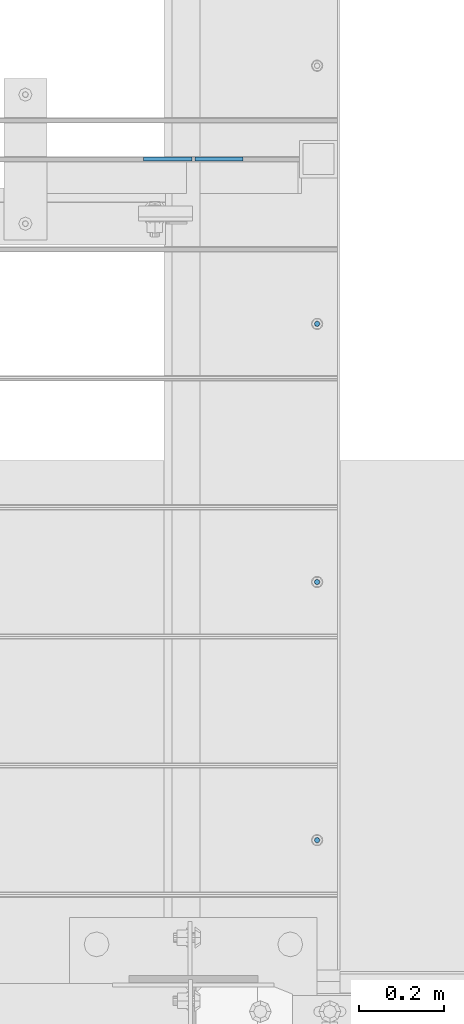
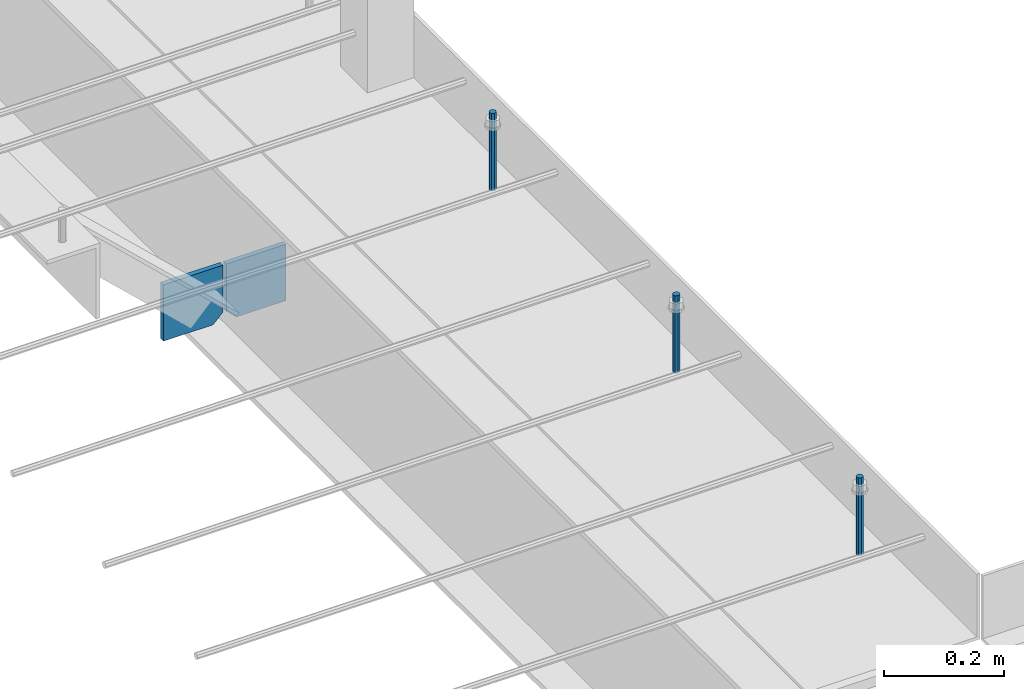
# One storey, part 385 of 1179: 5 columns, 1 element without a shape of its own.
"""IFC2X3 building model written with IfcOpenShell, lengths in millimetres."""

from ifc_helpers import new_model, si_unit, frame, origin_with_axes, place, context, subcontext, project, spatial, faceted_brep, material, type_object, element, aggregate, save


model = new_model("IFC2X3")

# Units and contexts
model_context = context("Model", 3, precision=1e-05, world=origin_with_axes())
body_context = subcontext(model_context, "Body", "Model", "MODEL_VIEW")
ifc_project = project(units=[si_unit("LENGTHUNIT", "METRE", prefix="MILLI"), si_unit("AREAUNIT", "SQUARE_METRE"), si_unit("VOLUMEUNIT", "CUBIC_METRE"), si_unit("MASSUNIT", "GRAM", prefix="KILO"), si_unit("TIMEUNIT", "SECOND"), si_unit("PLANEANGLEUNIT", "RADIAN"), si_unit("SOLIDANGLEUNIT", "STERADIAN"), si_unit("THERMODYNAMICTEMPERATUREUNIT", "DEGREE_CELSIUS"), si_unit("LUMINOUSINTENSITYUNIT", "LUMEN")], contexts=[model_context])

# Site, building, storey
site_placement = place(None, origin_with_axes())
site = spatial("IfcSite", under=ifc_project, at=site_placement, CompositionType="ELEMENT")
building_placement = place(site_placement, origin_with_axes())
building = spatial("IfcBuilding", under=site, at=building_placement, Name="Undefined", CompositionType="ELEMENT")
storey_placement = place(building_placement, origin_with_axes())
storey = spatial("IfcBuildingStorey", under=building, at=storey_placement, Name="Undefined", CompositionType="ELEMENT", Elevation=0.0)

# Assembly, columns
assembly_placement = place(storey_placement, origin_with_axes())
assembly = element("IfcElementAssembly", 1, at=assembly_placement, inside=storey, Name="BEAM", AssemblyPlace="NOTDEFINED", PredefinedType="RIGID_FRAME")
ifc_material_1 = material(Name="STEEL/A36")
column_type_1 = type_object("IfcColumnType", PredefinedType="NOTDEFINED")
column_1_placement = place(assembly_placement, frame((8220.075, 7518.40000000001, 3709.9875), z_axis=(1.0, 0.0, 0.0), x_axis=(0.0, 0.0, 1.0)))
column_1 = element("IfcColumn", 2, at=column_1_placement, type_object=column_type_1, material=ifc_material_1, Name="PLATE", context=body_context, shape_type="Brep", body=[
    faceted_brep([(19.0500000000002, 4.76250000000073, 57.1500000000015), (0.0, 4.76250000000073, 38.0999999999985), (0.0, -4.76250000000073, 38.0999999999985), (19.0500000000002, -4.76250000000073, 57.1500000000015), (114.300000000001, 4.76250000000073, 57.1500000000015), (114.300000000001, 4.76250000000073, -57.1500000000015), (0.0, 4.76250000000073, -57.1500000000015), (114.300000000001, -4.76250000000073, 57.1500000000015), (0.0, -4.76250000000073, -57.1500000000015), (114.300000000001, -4.76250000000073, -57.1500000000015)], [[[0, 1, 2, 3]], [[4, 5, 6, 1, 0]], [[7, 4, 0, 3]], [[8, 9, 7, 3, 2]], [[8, 6, 5, 9]], [[7, 9, 5, 4]], [[6, 8, 2, 1]]]),
])
column_2_placement = place(assembly_placement, frame((8340.725, 7518.40000000001, 3709.9875), z_axis=(-1.0, 0.0, 0.0), x_axis=(0.0, 0.0, 1.0)))
column_2 = element("IfcColumn", 3, at=column_2_placement, type_object=column_type_1, material=ifc_material_1, Name="PLATE", context=body_context, shape_type="Brep", body=[
    faceted_brep([(19.0500000000002, 4.76250000000073, 57.1500000000015), (0.0, 4.76250000000073, 38.0999999999985), (0.0, -4.76250000000073, 38.0999999999985), (19.0500000000002, -4.76250000000073, 57.1500000000015), (114.300000000001, 4.76250000000073, 57.1500000000015), (114.300000000001, 4.76250000000073, -57.1500000000015), (0.0, 4.76250000000073, -57.1500000000015), (114.300000000001, -4.76250000000073, 57.1500000000015), (0.0, -4.76250000000073, -57.1500000000015), (114.300000000001, -4.76250000000073, -57.1500000000015)], [[[0, 1, 2, 3]], [[4, 5, 6, 1, 0]], [[7, 4, 0, 3]], [[8, 9, 7, 3, 2]], [[8, 6, 5, 9]], [[7, 9, 5, 4]], [[6, 8, 2, 1]]]),
])
ifc_material_2 = material(Name="STEEL/A307")
column_type_2 = type_object("IfcColumnType", PredefinedType="NOTDEFINED")
column_3_placement = place(assembly_placement, frame((8572.5, 7129.4625, 4108.45), z_axis=(0.0, 1.0, 0.0), x_axis=(0.0, 0.0, 1.0)))
column_3 = element("IfcColumn", 4, at=column_3_placement, type_object=column_type_2, material=ifc_material_2, Name="THREADED ROD", context=body_context, shape_type="Brep", body=[
    faceted_brep([(0.0, -6.34999999999854, 0.0), (0.0, -4.49012806053361, -4.49012806053452), (157.162499999999, -4.49012806053361, -4.49012806053361), (157.162499999999, -6.34999999999854, 0.0), (0.0, 0.0, -6.34999999999991), (157.162499999999, 0.0, -6.34999999999854), (0.0, 4.49012806053361, -4.49012806053452), (157.162499999999, 4.49012806053361, -4.49012806053361), (0.0, 6.34999999999854, 0.0), (157.162499999999, 6.34999999999854, 0.0), (0.0, 4.49012806053361, 4.49012806053452), (157.162499999999, 4.49012806053361, 4.49012806053361), (0.0, 0.0, 6.34999999999991), (157.162499999999, 0.0, 6.34999999999854), (0.0, -4.49012806053361, 4.49012806053452), (157.162499999999, -4.49012806053361, 4.49012806053361)], [[[0, 1, 2, 3]], [[1, 4, 5, 2]], [[4, 6, 7, 5]], [[6, 8, 9, 7]], [[8, 10, 11, 9]], [[10, 12, 13, 11]], [[12, 14, 15, 13]], [[14, 0, 3, 15]], [[5, 7, 9, 11, 13, 15, 3, 2]], [[14, 12, 10, 8, 6, 4, 1, 0]]]),
])
column_4_placement = place(assembly_placement, frame((8572.5, 5910.2625, 4108.45), z_axis=(0.0, 1.0, 0.0), x_axis=(0.0, 0.0, 1.0)))
column_4 = element("IfcColumn", 5, at=column_4_placement, type_object=column_type_2, material=ifc_material_2, Name="THREADED ROD", context=body_context, shape_type="Brep", body=[
    faceted_brep([(0.0, -6.34999999999854, 0.0), (0.0, -4.49012806053361, -4.49012806053452), (157.162499999999, -4.49012806053361, -4.49012806053361), (157.162499999999, -6.34999999999854, 0.0), (0.0, 0.0, -6.34999999999991), (157.162499999999, 0.0, -6.34999999999854), (0.0, 4.49012806053361, -4.49012806053452), (157.162499999999, 4.49012806053361, -4.49012806053361), (0.0, 6.34999999999854, 0.0), (157.162499999999, 6.34999999999854, 0.0), (0.0, 4.49012806053361, 4.49012806053452), (157.162499999999, 4.49012806053361, 4.49012806053361), (0.0, 0.0, 6.34999999999991), (157.162499999999, 0.0, 6.34999999999854), (0.0, -4.49012806053361, 4.49012806053452), (157.162499999999, -4.49012806053361, 4.49012806053361)], [[[0, 1, 2, 3]], [[1, 4, 5, 2]], [[4, 6, 7, 5]], [[6, 8, 9, 7]], [[8, 10, 11, 9]], [[10, 12, 13, 11]], [[12, 14, 15, 13]], [[14, 0, 3, 15]], [[5, 7, 9, 11, 13, 15, 3, 2]], [[14, 12, 10, 8, 6, 4, 1, 0]]]),
])
column_5_placement = place(assembly_placement, frame((8572.5, 6519.8625, 4108.45), z_axis=(0.0, 1.0, 0.0), x_axis=(0.0, 0.0, 1.0)))
column_5 = element("IfcColumn", 6, at=column_5_placement, type_object=column_type_2, material=ifc_material_2, Name="THREADED ROD", context=body_context, shape_type="Brep", body=[
    faceted_brep([(0.0, -6.34999999999854, 0.0), (0.0, -4.49012806053361, -4.49012806053452), (157.162499999999, -4.49012806053361, -4.49012806053361), (157.162499999999, -6.34999999999854, 0.0), (0.0, 0.0, -6.34999999999991), (157.162499999999, 0.0, -6.34999999999854), (0.0, 4.49012806053361, -4.49012806053452), (157.162499999999, 4.49012806053361, -4.49012806053361), (0.0, 6.34999999999854, 0.0), (157.162499999999, 6.34999999999854, 0.0), (0.0, 4.49012806053361, 4.49012806053452), (157.162499999999, 4.49012806053361, 4.49012806053361), (0.0, 0.0, 6.34999999999991), (157.162499999999, 0.0, 6.34999999999854), (0.0, -4.49012806053361, 4.49012806053452), (157.162499999999, -4.49012806053361, 4.49012806053361)], [[[0, 1, 2, 3]], [[1, 4, 5, 2]], [[4, 6, 7, 5]], [[6, 8, 9, 7]], [[8, 10, 11, 9]], [[10, 12, 13, 11]], [[12, 14, 15, 13]], [[14, 0, 3, 15]], [[5, 7, 9, 11, 13, 15, 3, 2]], [[14, 12, 10, 8, 6, 4, 1, 0]]]),
])
aggregate(assembly, [column_3, column_4, column_5, column_1, column_2])

save(model, "model.ifc")
